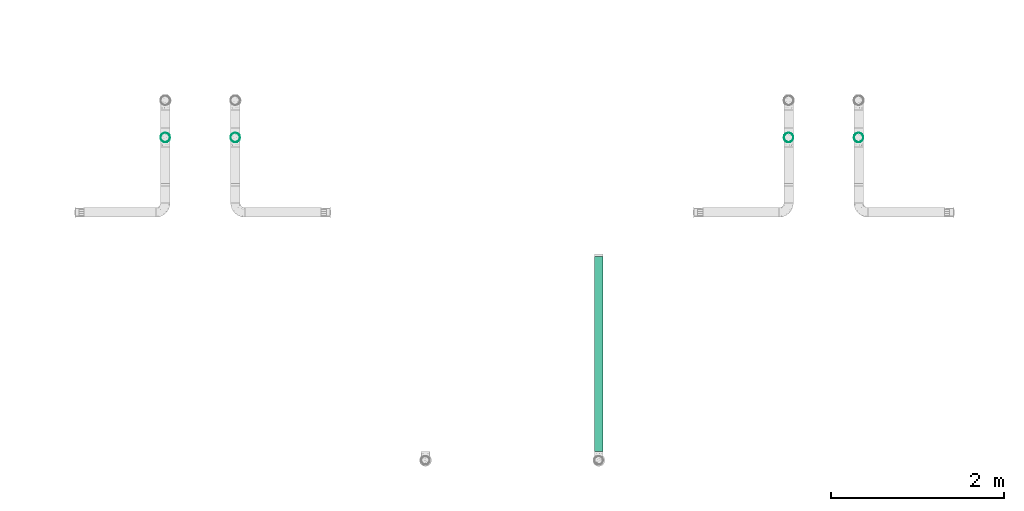
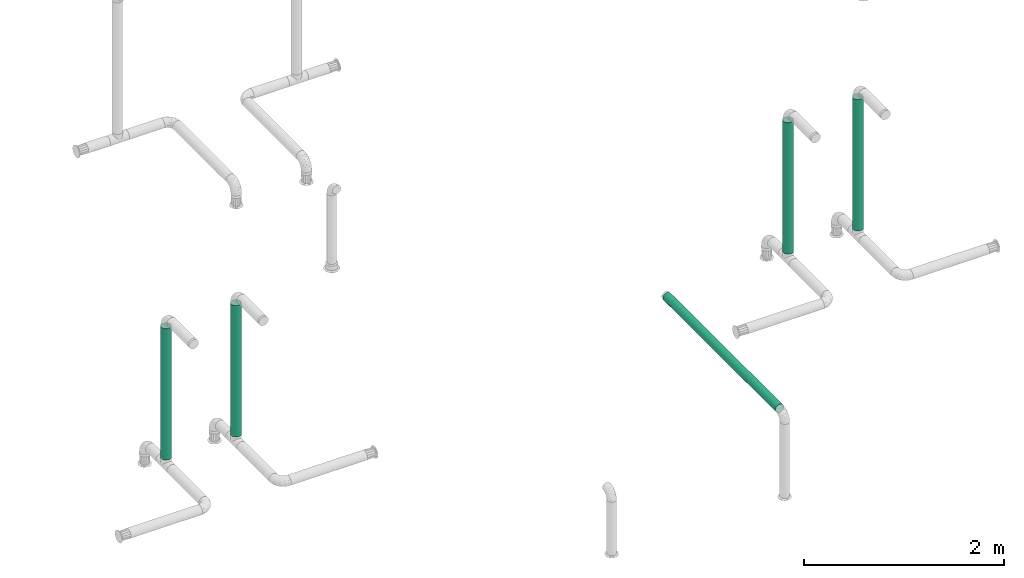
# One storey, part 1 of 103: 5 flow segments.
"""IFC2X3 building model written with IfcOpenShell, lengths in millimetres."""

from ifc_helpers import new_model, entity, si_unit, converted_unit, derived_unit, direction, frame, origin_with_axes, origin_2d_with_axis, place, context, subcontext, project, spatial, hollow_circle, extrude, source, transform, mapped, material, layer, layer_set, layer_usage, type_object, element, save


model = new_model("IFC2X3")

# Units and contexts
model_context = context("Model", 3, precision=1e-05, world=origin_with_axes(), true_north=direction((0.0, 1.0)))
body_context = subcontext(model_context, "Body", "Model", "MODEL_VIEW")
ifc_project = project(units=[si_unit("AREAUNIT", "SQUARE_METRE"), si_unit("VOLUMEUNIT", "CUBIC_METRE", prefix="DECI"), si_unit("TIMEUNIT", "SECOND"), si_unit("THERMODYNAMICTEMPERATUREUNIT", "DEGREE_CELSIUS"), si_unit("PRESSUREUNIT", "PASCAL"), si_unit("MASSUNIT", "GRAM", prefix="KILO"), si_unit("LENGTHUNIT", "METRE", prefix="MILLI"), si_unit("POWERUNIT", "WATT"), si_unit("ELECTRICCURRENTUNIT", "AMPERE"), si_unit("ELECTRICVOLTAGEUNIT", "VOLT"), derived_unit("VOLUMETRICFLOWRATEUNIT", [(si_unit("VOLUMEUNIT", "CUBIC_METRE", prefix="DECI"), 1), (si_unit("TIMEUNIT", "SECOND"), -1)]), derived_unit("LINEARVELOCITYUNIT", [(si_unit("LENGTHUNIT", "METRE"), 1), (si_unit("TIMEUNIT", "SECOND"), -1)]), derived_unit("MASSDENSITYUNIT", [(si_unit("MASSUNIT", "GRAM", prefix="KILO"), 1), (si_unit("VOLUMEUNIT", "CUBIC_METRE"), -1)]), converted_unit("PLANEANGLEUNIT", "DEGREE", entity("IfcRatioMeasure", 0.01745), si_unit("PLANEANGLEUNIT", "RADIAN"), dimensions=[0, 0, 0, 0, 0, 0, 0])], contexts=[model_context])

# Site, building, storey
site_placement = place(None, origin_with_axes())
site = spatial("IfcSite", under=ifc_project, at=site_placement, CompositionType="ELEMENT")
building_placement = place(site_placement, origin_with_axes())
building = spatial("IfcBuilding", under=site, at=building_placement, Name="mc-building", CompositionType="ELEMENT")
storey_placement = place(building_placement, frame((0.0, 0.0, 5900.0), z_axis=(0.0, 0.0, 1.0), x_axis=(1.0, 0.0, 0.0)))
storey = spatial("IfcBuildingStorey", under=building, at=storey_placement, Name="3. Korrus", CompositionType="ELEMENT", Elevation=5900.0)

# Flow segments
ifc_material = material(Name="FZ1")
ifc_layer = layer(ifc_material, 0.0)
ifc_layer_set = layer_set([ifc_layer], Name="FZ1")
ifc_layer_usage = layer_usage(ifc_layer_set, "AXIS1", "POSITIVE", 0.0)
duct_segment_type_1 = type_object("IfcDuctSegmentType", PredefinedType="RIGIDSEGMENT")
shared_shape_1 = source(origin_with_axes(), body_context, "Body", "SweptSolid", [
    extrude(hollow_circle(Radius=50.0, WallThickness=2.0, at=origin_2d_with_axis()), frame((0.0, 0.0, 0.0), z_axis=(1.0, 0.0, 0.0), x_axis=(0.0, 1.0, 0.0)), (0.0, 0.0, 1.0), 2257.3),
])
flow_segment_placement = place(storey_placement, frame((13392.97051, 673.88887, 3468.0), z_axis=(0.0, 0.0, 1.0), x_axis=(0.0, 1.0, 0.0)))
element("IfcFlowSegment", 1, at=flow_segment_placement, inside=storey, type_object=duct_segment_type_1, material=ifc_layer_usage, context=body_context, shape_type="MappedRepresentation", body=[
    mapped(shared_shape_1, transform((0.0, 0.0, 0.0), scale=1.0)),
])
duct_segment_type_2 = type_object("IfcDuctSegmentType", Name="Safe", PredefinedType="RIGIDSEGMENT")
shared_shape_2 = source(origin_with_axes(), body_context, "Body", "SweptSolid", [
    extrude(hollow_circle(Radius=55.0, WallThickness=2.0, at=origin_2d_with_axis()), frame((0.0, 0.0, 0.0), z_axis=(1.0, 0.0, 0.0), x_axis=(0.0, 1.0, 0.0)), (0.0, 0.0, 1.0), 1609.0),
])
for number, where, z_axis, x_axis, name in (
    (2, (16394.13313, 4302.28735, 2425.0), (0.0, -1.0, 0.0), (0.0, 0.0, 1.0), "Safe"),
    (3, (15585.80789, 4302.28735, 2425.0), (0.0, -1.0, 0.0), (0.0, 0.0, 1.0), "Safe"),
    (4, (9194.13313, 4302.28735, 2425.0), (0.0, -1.0, 0.0), (0.0, 0.0, 1.0), "Safe"),
    (5, (8385.80789, 4302.28735, 2425.0), (0.0, -1.0, 0.0), (0.0, 0.0, 1.0), "Safe"),
):
    element("IfcFlowSegment", number, at=place(storey_placement, frame(where, z_axis=z_axis, x_axis=x_axis)), inside=storey, type_object=duct_segment_type_2, material=ifc_layer_usage, Name=name, context=body_context, shape_type="MappedRepresentation", body=[
        mapped(shared_shape_2, transform((0.0, 0.0, 0.0), scale=1.0)),
    ])

save(model, "model.ifc")
